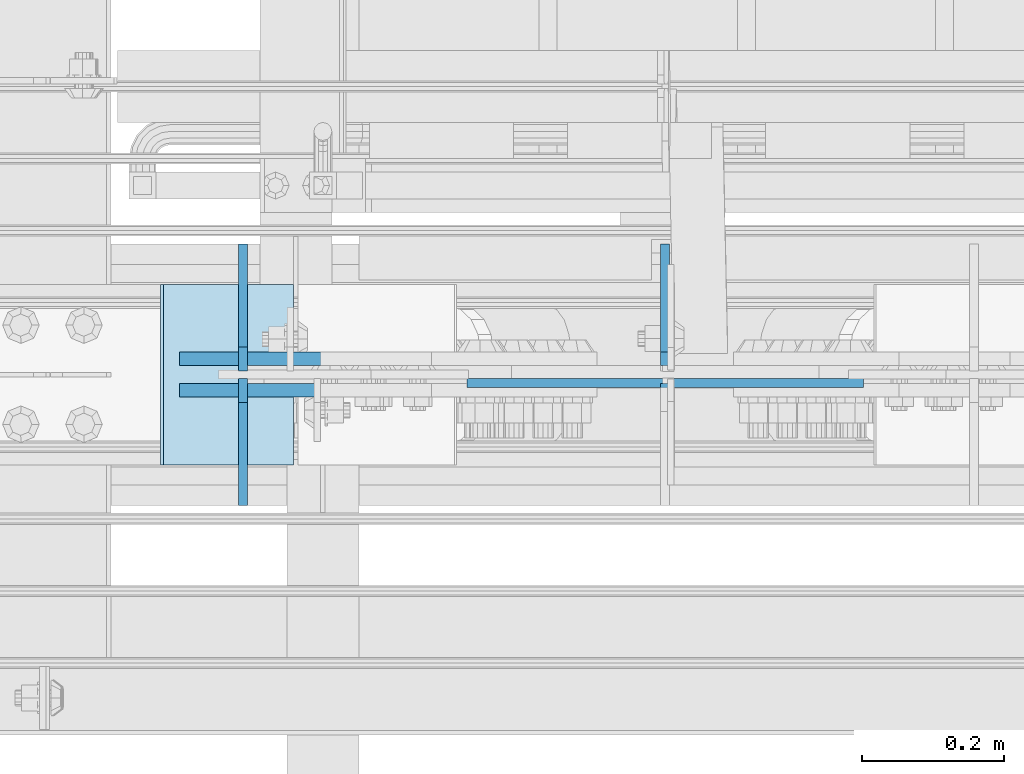
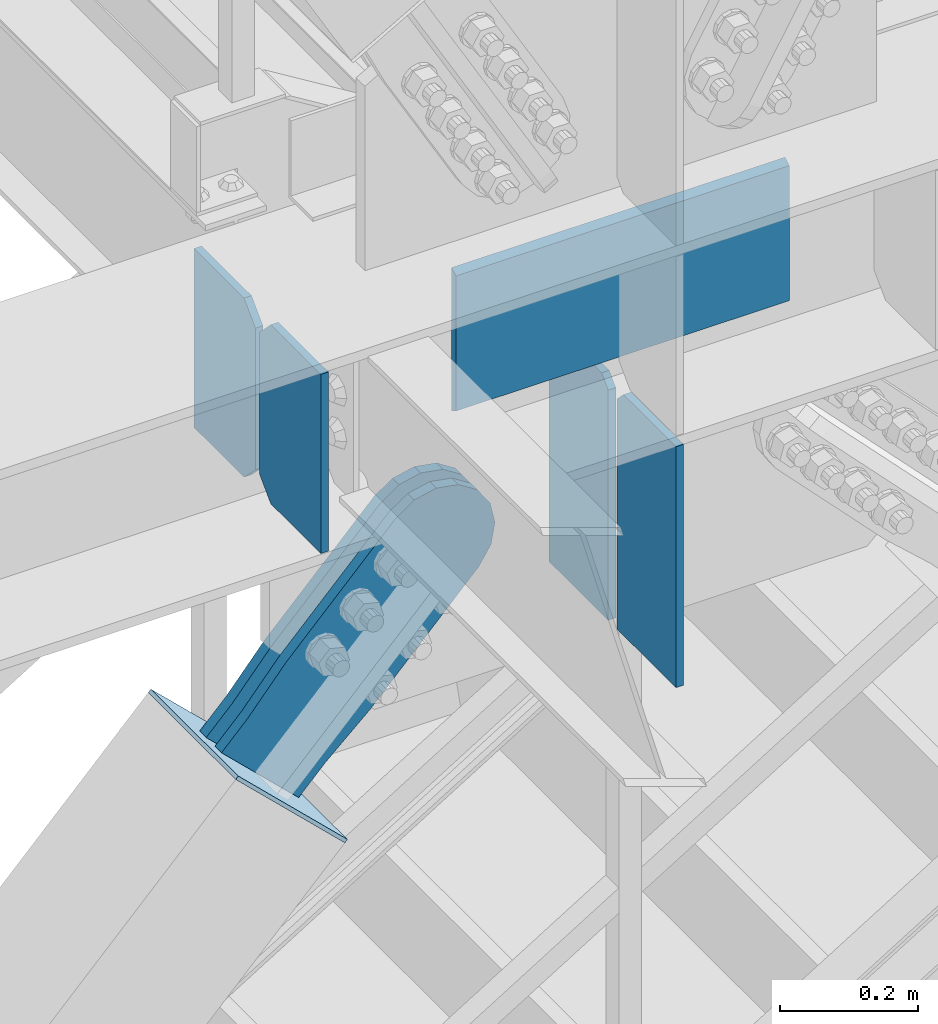
# One storey, part 3549 of 3843: 8 plates, 4 elements without a shape of their own.
"""IFC2X3 building model written with IfcOpenShell, lengths in millimetres."""

from ifc_helpers import new_model, si_unit, frame, origin_with_axes, place, context, subcontext, project, spatial, faceted_brep, material, type_object, element, aggregate, save


model = new_model("IFC2X3")

# Units and contexts
model_context = context("Model", 3, precision=1e-05, world=origin_with_axes())
body_context = subcontext(model_context, "Body", "Model", "MODEL_VIEW")
ifc_project = project(units=[si_unit("LENGTHUNIT", "METRE", prefix="MILLI"), si_unit("AREAUNIT", "SQUARE_METRE"), si_unit("VOLUMEUNIT", "CUBIC_METRE"), si_unit("MASSUNIT", "GRAM", prefix="KILO"), si_unit("TIMEUNIT", "SECOND"), si_unit("PLANEANGLEUNIT", "RADIAN"), si_unit("SOLIDANGLEUNIT", "STERADIAN"), si_unit("THERMODYNAMICTEMPERATUREUNIT", "DEGREE_CELSIUS"), si_unit("LUMINOUSINTENSITYUNIT", "LUMEN")], contexts=[model_context])

# Site, building, storey
site_placement = place(None, origin_with_axes())
site = spatial("IfcSite", under=ifc_project, at=site_placement, CompositionType="ELEMENT")
building_placement = place(site_placement, origin_with_axes())
building = spatial("IfcBuilding", under=site, at=building_placement, Name="Undefined", CompositionType="ELEMENT")
storey_placement = place(building_placement, origin_with_axes())
storey = spatial("IfcBuildingStorey", under=building, at=storey_placement, Name="Undefined", CompositionType="ELEMENT", Elevation=0.0)

# Assembly, plates
assembly_1_placement = place(storey_placement, origin_with_axes())
assembly_1 = element("IfcElementAssembly", 1, at=assembly_1_placement, inside=storey, Name="BEAM", AssemblyPlace="NOTDEFINED", PredefinedType="RIGID_FRAME")
ifc_material_1 = material(Name="STEEL/A572-50")
plate_type_1 = type_object("IfcPlateType", PredefinedType="NOTDEFINED")
plate_1_placement = place(assembly_1_placement, frame((80735.4874999999, 15004.25625, 34474.15), z_axis=(0.0, 1.0, 0.0), x_axis=(0.0, 0.0, 1.0)))
plate_1 = element("IfcPlate", 2, at=plate_1_placement, type_object=plate_type_1, material=ifc_material_1, Name="CB_BEAM", context=body_context, shape_type="Brep", body=[
    faceted_brep([(0.0, -6.34999999999854, 33.3375015258789), (0.0, -6.34999999999854, 178.59375), (0.0, 6.34999999999854, 178.59375), (0.0, 6.34999999999854, 33.3375015258789), (317.499999999985, -6.34999999999854, 178.59375), (317.499999999985, 6.34999999999854, 178.59375), (317.499999999985, -6.34999999999854, 33.3375015258789), (317.499999999985, 6.34999999999854, 33.3375015258789), (284.162498474107, -6.34999999999854, 0.0), (284.162498474107, 6.34999999999854, 0.0), (33.3375015258789, -6.34999999999854, 0.0), (33.3375015258789, 6.34999999999854, 0.0)], [[[0, 1, 2, 3]], [[1, 4, 5, 2]], [[4, 6, 7, 5]], [[6, 8, 9, 7]], [[8, 10, 11, 9]], [[10, 0, 3, 11]], [[5, 7, 9, 11, 3, 2]], [[10, 8, 6, 4, 1, 0]]]),
])
plate_2_placement = place(assembly_1_placement, frame((80735.4874999999, 14993.14375, 34474.15), z_axis=(0.0, -1.0, 0.0), x_axis=(0.0, 0.0, 1.0)))
plate_2 = element("IfcPlate", 3, at=plate_2_placement, type_object=plate_type_1, material=ifc_material_1, Name="CB_BEAM", context=body_context, shape_type="Brep", body=[
    faceted_brep([(0.0, -6.34999999999854, 33.3375015258789), (0.0, -6.34999999999854, 178.59375), (0.0, 6.34999999999854, 178.59375), (0.0, 6.34999999999854, 33.3375015258789), (317.499999999985, -6.34999999999854, 178.59375), (317.499999999985, 6.34999999999854, 178.59375), (317.499999999985, -6.34999999999854, 33.3375015258789), (317.499999999985, 6.34999999999854, 33.3375015258789), (284.162498474107, -6.34999999999854, 0.0), (284.162498474107, 6.34999999999854, 0.0), (33.3375015258789, -6.34999999999854, 0.0), (33.3375015258789, 6.34999999999854, 0.0)], [[[0, 1, 2, 3]], [[1, 4, 5, 2]], [[4, 6, 7, 5]], [[6, 8, 9, 7]], [[8, 10, 11, 9]], [[10, 0, 3, 11]], [[5, 7, 9, 11, 3, 2]], [[10, 8, 6, 4, 1, 0]]]),
])
plate_type_2 = type_object("IfcPlateType", PredefinedType="NOTDEFINED")
plate_3_placement = place(assembly_1_placement, frame((81051.4, 14986.79375, 34759.9), z_axis=(1.0, 0.0, 0.0), x_axis=(0.0, 0.0, -1.0)))
plate_3 = element("IfcPlate", 4, at=plate_3_placement, type_object=plate_type_2, material=ifc_material_1, Name="PLATE", context=body_context, shape_type="Brep", body=[
    faceted_brep([(246.667651583113, -6.35000000000036, 0.0), (253.999999999993, 6.35000000000036, 0.0), (253.999999999993, 6.35000000000036, 558.799999999988), (246.667651583113, -6.35000000000036, 558.799999999988), (7.33234841688682, -6.35000000000036, 558.799999999988), (7.33234841688682, -6.35000000000036, 0.0), (7.27595761418343e-12, 6.3499999046162, 0.0), (0.0, 6.35000000000036, 558.799999999988)], [[[0, 1, 2, 3]], [[0, 3, 4, 5]], [[1, 0, 5, 6]], [[2, 1, 6, 7]], [[3, 2, 7, 4]], [[6, 5, 4, 7]]]),
])

# Assembly, plate
assembly_2_placement = place(storey_placement, origin_with_axes())
assembly_2 = element("IfcElementAssembly", 5, at=assembly_2_placement, inside=storey, AssemblyPlace="NOTDEFINED", PredefinedType="RIGID_FRAME")
ifc_material_2 = material(Name="STEEL/A36")
plate_type_3 = type_object("IfcPlateType", PredefinedType="NOTDEFINED")
plate_4_placement = place(assembly_2_placement, frame((80775.5970566937, 15020.925, 33926.9844257342), z_axis=(-0.720244694304652, 0.0, 0.693720102293424), x_axis=(0.693720102293431, 0.0, 0.720244694304645)))
plate_4 = element("IfcPlate", 6, at=plate_4_placement, type_object=plate_type_3, material=ifc_material_2, context=body_context, shape_type="Brep", body=[
    faceted_brep([(0.0, -9.52500000000146, 0.0), (7.37782102078199e-09, -9.52499999999418, 179.651701450231), (7.37782102078199e-09, 9.52499999999418, 179.651701450231), (0.0, 9.52500000000146, 0.0), (69.8500000062704, -9.52499999999418, 179.651701450392), (69.8500000062704, 9.52499999999418, 179.651701450392), (171.449999998309, -9.52499999999418, 186.663350727089), (171.449999998309, 9.52499999999418, 186.663350727089), (434.579297655291, -9.52499999999418, 186.663350728457), (434.579297655291, 9.52499999999418, 186.663350728457), (471.637405120986, -9.52499999999418, 179.292034842016), (471.637405120986, 9.52499999999418, 179.292034842016), (503.05375165752, -9.52499999999418, 158.300303204887), (503.05375165752, 9.52499999999418, 158.300303204887), (524.045483294532, -9.52499999999418, 126.883956668345), (524.045483294532, 9.52499999999418, 126.883956668345), (531.416799180792, -9.52499999999418, 89.8258522538526), (531.416799180792, 9.52499999999418, 89.8258522538526), (524.045483293885, -9.52499999999418, 52.7677447886235), (524.045483293885, 9.52499999999418, 52.7677447886235), (503.053751656611, -9.52499999999418, 21.3513982523873), (503.053751656611, 9.52499999999418, 21.3513982523873), (471.637405120178, -9.52499999999418, 0.359666615346214), (471.637405120178, 9.52499999999418, 0.359666615346214), (434.579299181831, -9.52499999999418, -7.01164927131322), (434.579299181831, 9.52499999999418, -7.01164927131322), (171.449999996272, -9.52499999999418, -7.01164927269565), (171.449999996272, 9.52499999999418, -7.01164927269565), (69.8499999979995, -9.52499999999418, -4.00177668780088e-10), (69.8499999979995, 9.52499999999418, -4.00177668780088e-10)], [[[0, 1, 2, 3]], [[1, 4, 5, 2]], [[4, 6, 7, 5]], [[6, 8, 9, 7]], [[8, 10, 11, 9]], [[10, 12, 13, 11]], [[12, 14, 15, 13]], [[14, 16, 17, 15]], [[16, 18, 19, 17]], [[18, 20, 21, 19]], [[20, 22, 23, 21]], [[22, 24, 25, 23]], [[24, 26, 27, 25]], [[26, 28, 29, 27]], [[28, 0, 3, 29]], [[5, 7, 9, 11, 13, 15, 17, 19, 21, 23, 25, 27, 29, 3, 2]], [[28, 26, 24, 22, 20, 18, 16, 14, 12, 10, 8, 6, 4, 1, 0]]]),
])
aggregate(assembly_2, [plate_4])

assembly_3_placement = place(storey_placement, origin_with_axes())
assembly_3 = element("IfcElementAssembly", 7, at=assembly_3_placement, inside=storey, AssemblyPlace="NOTDEFINED", PredefinedType="RIGID_FRAME")
plate_5_placement = place(assembly_3_placement, frame((80775.5970566937, 14976.475, 33926.9844257342), z_axis=(-0.720244694304652, 0.0, 0.693720102293424), x_axis=(0.693720102293431, 0.0, 0.720244694304645)))
plate_5 = element("IfcPlate", 8, at=plate_5_placement, type_object=plate_type_3, material=ifc_material_2, context=body_context, shape_type="Brep", body=[
    faceted_brep([(0.0, -9.52500000000146, 0.0), (7.37782102078199e-09, -9.52499999999418, 179.651701450231), (7.37782102078199e-09, 9.52499999999418, 179.651701450231), (0.0, 9.52500000000146, 0.0), (69.8500000062704, -9.52499999999418, 179.651701450392), (69.8500000062704, 9.52499999999418, 179.651701450392), (171.449999998309, -9.52499999999418, 186.663350727089), (171.449999998309, 9.52499999999418, 186.663350727089), (434.579297655291, -9.52499999999418, 186.663350728457), (434.579297655291, 9.52499999999418, 186.663350728457), (471.637405120986, -9.52499999999418, 179.292034842016), (471.637405120986, 9.52499999999418, 179.292034842016), (503.05375165752, -9.52499999999418, 158.300303204887), (503.05375165752, 9.52499999999418, 158.300303204887), (524.045483294532, -9.52499999999418, 126.883956668345), (524.045483294532, 9.52499999999418, 126.883956668345), (531.416799180792, -9.52499999999418, 89.8258522538526), (531.416799180792, 9.52499999999418, 89.8258522538526), (524.045483293885, -9.52499999999418, 52.7677447886235), (524.045483293885, 9.52499999999418, 52.7677447886235), (503.053751656611, -9.52499999999418, 21.3513982523873), (503.053751656611, 9.52499999999418, 21.3513982523873), (471.637405120178, -9.52499999999418, 0.359666615346214), (471.637405120178, 9.52499999999418, 0.359666615346214), (434.579299181831, -9.52499999999418, -7.01164927131322), (434.579299181831, 9.52499999999418, -7.01164927131322), (171.449999996272, -9.52499999999418, -7.01164927269565), (171.449999996272, 9.52499999999418, -7.01164927269565), (69.8499999979995, -9.52499999999418, -4.00177668780088e-10), (69.8499999979995, 9.52499999999418, -4.00177668780088e-10)], [[[0, 1, 2, 3]], [[1, 4, 5, 2]], [[4, 6, 7, 5]], [[6, 8, 9, 7]], [[8, 10, 11, 9]], [[10, 12, 13, 11]], [[12, 14, 15, 13]], [[14, 16, 17, 15]], [[16, 18, 19, 17]], [[18, 20, 21, 19]], [[20, 22, 23, 21]], [[22, 24, 25, 23]], [[24, 26, 27, 25]], [[26, 28, 29, 27]], [[28, 0, 3, 29]], [[5, 7, 9, 11, 13, 15, 17, 19, 21, 23, 25, 27, 29, 3, 2]], [[28, 26, 24, 22, 20, 18, 16, 14, 12, 10, 8, 6, 4, 1, 0]]]),
])
aggregate(assembly_3, [plate_5])

assembly_4_placement = place(storey_placement, origin_with_axes())
assembly_4 = element("IfcElementAssembly", 9, at=assembly_4_placement, inside=storey, Name="Plate", AssemblyPlace="NOTDEFINED", PredefinedType="RIGID_FRAME")
plate_type_4 = type_object("IfcPlateType", PredefinedType="NOTDEFINED")
plate_6_placement = place(assembly_4_placement, frame((80804.5741018486, 14871.7, 33903.4827479412), z_axis=(-0.720244694304652, 0.0, 0.693720102293424), x_axis=(0.0, 1.0, 0.0)))
plate_6 = element("IfcPlate", 10, at=plate_6_placement, type_object=plate_type_4, material=ifc_material_2, Name="Plate", context=body_context, shape_type="Brep", body=[
    faceted_brep([(0.0, -3.17499999999927, 0.0), (0.0, -3.17499999965185, 254.000000005151), (0.0, 3.17500000035216, 254.000000005166), (0.0, 3.17499999999927, 0.0), (254.0, -3.17499999965185, 254.000000005151), (254.0, 3.17500000035216, 254.000000005166), (254.0, -3.17500000000291, 0.0), (254.0, 3.17499999999927, 1.45519152283669e-11)], [[[0, 1, 2, 3]], [[1, 4, 5, 2]], [[4, 6, 7, 5]], [[6, 0, 3, 7]], [[5, 7, 3, 2]], [[6, 4, 1, 0]]]),
])
aggregate(assembly_4, [plate_6])

# Plate
plate_type_5 = type_object("IfcPlateType", PredefinedType="NOTDEFINED")
plate_7_placement = place(assembly_1_placement, frame((81330.7999999999, 15011.4, 34027.9857647562), z_axis=(0.0, 1.0, 0.0), x_axis=(0.0, 0.0, 1.0)))
plate_7 = element("IfcPlate", 11, at=plate_7_placement, type_object=plate_type_5, material=ifc_material_1, Name="CB", context=body_context, shape_type="Brep", body=[
    faceted_brep([(0.0, -6.3499999046162, 0.0), (0.0, -6.35000000000582, 171.449999999999), (0.0, 6.35000000000582, 171.449999999999), (7.27595761418343e-12, 6.3499999046162, 0.0), (427.114235243775, -6.35000000000582, 171.449999999999), (427.114235243775, 6.35000000000582, 171.449999999999), (427.114235243775, -6.35000000000582, 19.0499992370605), (427.114235243775, 6.35000000000582, 19.0499992370605), (408.064236006714, -6.35000000000582, 0.0), (408.064236006714, 6.35000000000582, 0.0)], [[[0, 1, 2, 3]], [[1, 4, 5, 2]], [[4, 6, 7, 5]], [[6, 8, 9, 7]], [[8, 0, 3, 9]], [[5, 7, 9, 3, 2]], [[8, 6, 4, 1, 0]]]),
])

plate_8_placement = place(assembly_1_placement, frame((81330.7999999999, 14986.0, 34027.9857647562), z_axis=(0.0, -1.0, 0.0), x_axis=(0.0, 0.0, 1.0)))
plate_8 = element("IfcPlate", 12, at=plate_8_placement, type_object=plate_type_5, material=ifc_material_1, Name="CB", context=body_context, shape_type="Brep", body=[
    faceted_brep([(0.0, -6.3499999046162, 0.0), (0.0, -6.35000000000582, 171.449999999999), (0.0, 6.35000000000582, 171.449999999999), (7.27595761418343e-12, 6.3499999046162, 0.0), (427.114235243775, -6.35000000000582, 171.449999999999), (427.114235243775, 6.35000000000582, 171.449999999999), (427.114235243775, -6.35000000000582, 19.0499992370605), (427.114235243775, 6.35000000000582, 19.0499992370605), (408.064236006714, -6.35000000000582, 0.0), (408.064236006714, 6.35000000000582, 0.0)], [[[0, 1, 2, 3]], [[1, 4, 5, 2]], [[4, 6, 7, 5]], [[6, 8, 9, 7]], [[8, 0, 3, 9]], [[5, 7, 9, 3, 2]], [[8, 6, 4, 1, 0]]]),
])

aggregate(assembly_1, [plate_1, plate_2, plate_3, plate_7, plate_8])

save(model, "model.ifc")
